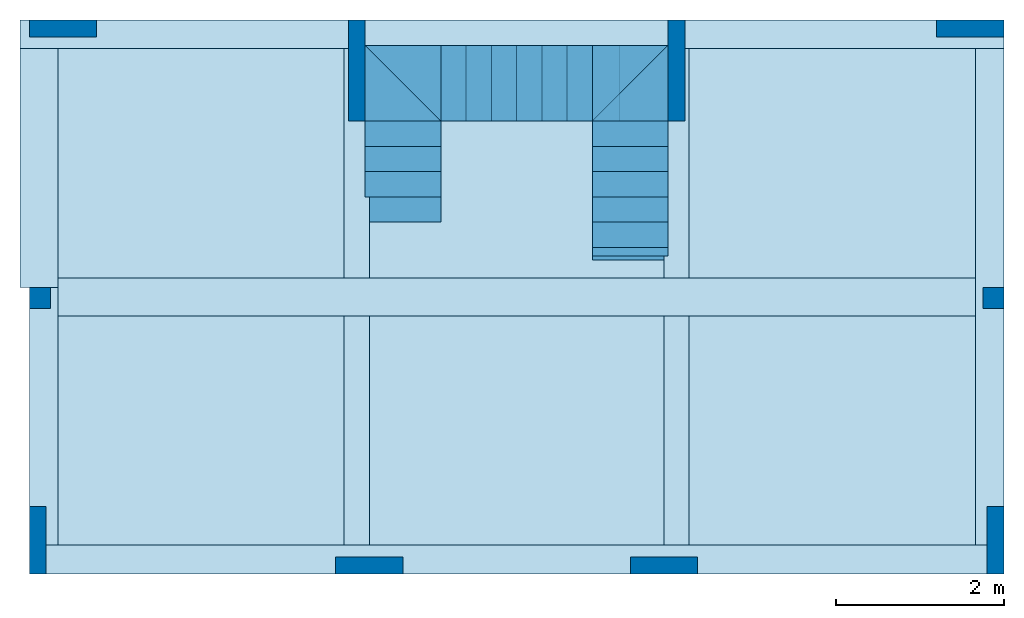
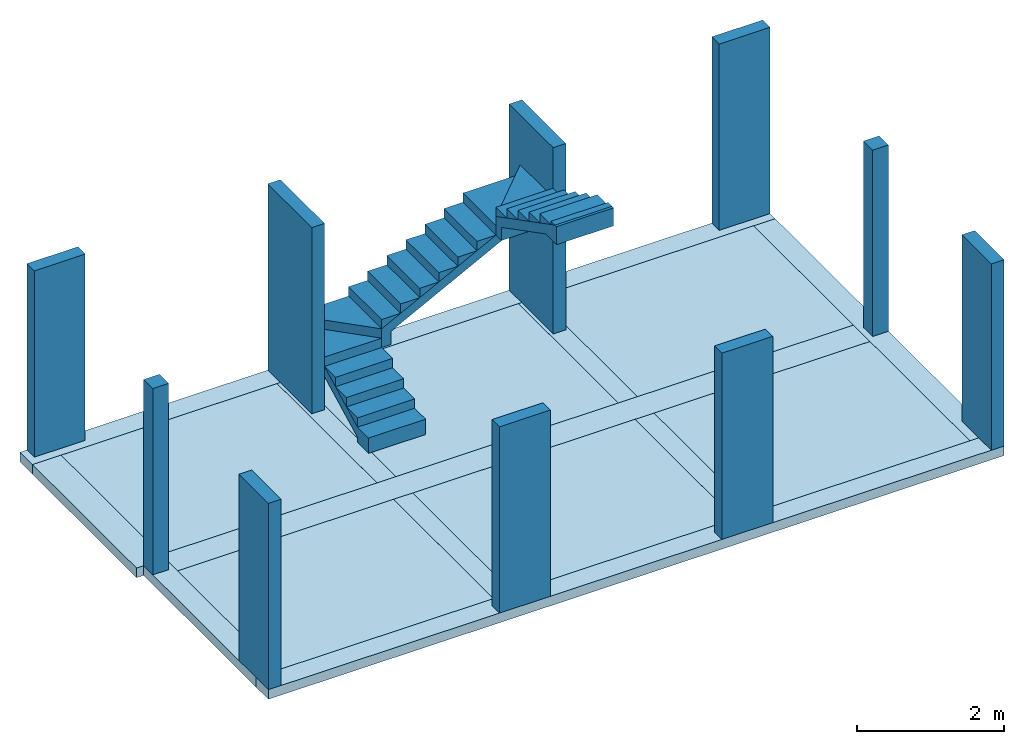
# One storey: 19 stairs, 16 slabs, 10 columns, 3 stair flights.
"""IFC4 building model written with IfcOpenShell, lengths in metres."""

from ifc_helpers import new_model, entity, si_unit, converted_unit, direction, frame, frame_2d, origin_with_axes, origin_2d_with_axis, place, context, subcontext, project, spatial, polyline, rectangle, outline, extrude, element, save


model = new_model("IFC4")

# Units and contexts
model_context = context("Model", 3, precision=1e-05, world=origin_with_axes(), true_north=direction((6.12323399573677e-17, 1.0)))
body_context = subcontext(model_context, "Body", "Model", "MODEL_VIEW")
ifc_project = project(units=[si_unit("LENGTHUNIT", "METRE"), si_unit("AREAUNIT", "SQUARE_METRE"), si_unit("VOLUMEUNIT", "CUBIC_METRE"), converted_unit("PLANEANGLEUNIT", "DEGREE", entity("IfcPlaneAngleMeasure", 0.017453292519943295), si_unit("PLANEANGLEUNIT", "RADIAN"), dimensions=[0, 0, 0, 0, 0, 0, 0])], contexts=[model_context])

# Site, building, storey
site = spatial("IfcSite", under=ifc_project, CompositionType="COMPLEX")
building = spatial("IfcBuilding", under=site, Name="Italian House", CompositionType="COMPLEX")
storey_placement = place(None, frame((0.0, 0.0, -0.300000011920929), z_axis=(0.0, 0.0, 1.0), x_axis=(1.0, 0.0, 0.0)))
storey = spatial("IfcBuildingStorey", under=building, at=storey_placement, Name="Piano terra")

# Columns
column_1_placement = place(storey_placement, frame((0.0, 0.0, 0.300000011920929), z_axis=(0.0, 0.0, 1.0), x_axis=(1.0, 0.0, 0.0)))
element("IfcColumn", 1, at=column_1_placement, inside=storey, Name="P008_1", PredefinedType="COLUMN", context=body_context, shape_type="SweptSolid", body=[
    extrude(rectangle(XDim=0.2, YDim=0.8, at=frame_2d((3.30681662608084e-18, 1.21430643318376e-17), x_axis=(1.0, 0.0))), frame((15.83, -6.18, 0.46), z_axis=(0.0, 0.0, 1.0), x_axis=(1.0, 0.0, 0.0)), (0.0, 0.0, 1.0), 3.1),
])
column_2_placement = place(storey_placement, frame((0.0, 0.0, 0.300000011920929), z_axis=(0.0, 0.0, 1.0), x_axis=(1.0, 0.0, 0.0)))
element("IfcColumn", 2, at=column_2_placement, inside=storey, Name="P004_1", PredefinedType="COLUMN", context=body_context, shape_type="SweptSolid", body=[
    extrude(rectangle(XDim=0.2, YDim=1.2, at=frame_2d((3.30681662608079e-18, -2.42861286636753e-17), x_axis=(1.0, 0.0))), frame((8.24, -0.599999999999998, 0.46), z_axis=(0.0, 0.0, 1.0), x_axis=(1.0, 0.0, 0.0)), (0.0, 0.0, 1.0), 3.1),
])
column_3_placement = place(storey_placement, frame((0.0, 0.0, 0.300000011920929), z_axis=(0.0, 0.0, 1.0), x_axis=(1.0, 0.0, 0.0)))
element("IfcColumn", 3, at=column_3_placement, inside=storey, Name="P005_1", PredefinedType="COLUMN", context=body_context, shape_type="SweptSolid", body=[
    extrude(rectangle(XDim=0.2, YDim=1.2, at=frame_2d((3.30681662608079e-18, -2.42861286636753e-17), x_axis=(1.0, 0.0))), frame((12.04, -0.599999999999997, 0.46), z_axis=(0.0, 0.0, 1.0), x_axis=(1.0, 0.0, 0.0)), (0.0, 0.0, 1.0), 3.1),
])
column_4_placement = place(storey_placement, frame((0.0, 0.0, 0.300000011920929), z_axis=(0.0, 0.0, 1.0), x_axis=(1.0, 0.0, 0.0)))
element("IfcColumn", 4, at=column_4_placement, inside=storey, Name="P010_1", PredefinedType="COLUMN", context=body_context, shape_type="SweptSolid", body=[
    extrude(rectangle(XDim=0.8, YDim=0.2, at=frame_2d((1.32272665043234e-17, 3.03576608295941e-18), x_axis=(1.0, 0.0))), frame((8.39000001192093, -6.48000000596046, 0.46), z_axis=(0.0, 0.0, 1.0), x_axis=(0.999999999999993, -1.19209275e-07, 0.0)), (0.0, 0.0, 1.0), 3.1),
])
column_5_placement = place(storey_placement, frame((0.0, 0.0, 0.300000011920929), z_axis=(0.0, 0.0, 1.0), x_axis=(1.0, 0.0, 0.0)))
element("IfcColumn", 5, at=column_5_placement, inside=storey, Name="P009_1", PredefinedType="COLUMN", context=body_context, shape_type="SweptSolid", body=[
    extrude(rectangle(XDim=0.8, YDim=0.2, at=frame_2d((1.32272665043234e-17, 3.03576608295941e-18), x_axis=(1.0, 0.0))), frame((11.8900000119209, -6.47999999403953, 0.46), z_axis=(0.0, 0.0, 1.0), x_axis=(0.999999999999993, -1.19209275e-07, 0.0)), (0.0, 0.0, 1.0), 3.1),
])
column_6_placement = place(storey_placement, frame((0.0, 0.0, 0.300000011920929), z_axis=(0.0, 0.0, 1.0), x_axis=(1.0, 0.0, 0.0)))
element("IfcColumn", 6, at=column_6_placement, inside=storey, Name="P002_1", PredefinedType="COLUMN", context=body_context, shape_type="SweptSolid", body=[
    extrude(rectangle(XDim=0.25, YDim=0.25, at=frame_2d((2.00577401909818e-18, 3.46944695195361e-18), x_axis=(1.0, 0.0))), frame((4.475, -3.305, 0.46), z_axis=(0.0, 0.0, 1.0), x_axis=(1.0, 0.0, 0.0)), (0.0, 0.0, 1.0), 3.1),
])
column_7_placement = place(storey_placement, frame((0.0, 0.0, 0.300000011920929), z_axis=(0.0, 0.0, 1.0), x_axis=(1.0, 0.0, 0.0)))
element("IfcColumn", 7, at=column_7_placement, inside=storey, Name="P007_1", PredefinedType="COLUMN", context=body_context, shape_type="SweptSolid", body=[
    extrude(rectangle(XDim=0.25, YDim=0.25, at=frame_2d((2.00577401909818e-18, 3.46944695195361e-18), x_axis=(1.0, 0.0))), frame((15.805, -3.305, 0.46), z_axis=(0.0, 0.0, 1.0), x_axis=(1.0, 0.0, 0.0)), (0.0, 0.0, 1.0), 3.1),
])
column_8_placement = place(storey_placement, frame((0.0, 0.0, 0.300000011920929), z_axis=(0.0, 0.0, 1.0), x_axis=(1.0, 0.0, 0.0)))
element("IfcColumn", 8, at=column_8_placement, inside=storey, Name="P003_1", PredefinedType="COLUMN", context=body_context, shape_type="SweptSolid", body=[
    extrude(rectangle(XDim=0.8, YDim=0.2, at=frame_2d((1.32272665043234e-17, 3.03576608295941e-18), x_axis=(1.0, 0.0))), frame((4.75, -0.0999999999999982, 0.46), z_axis=(0.0, 0.0, 1.0), x_axis=(1.0, 0.0, 0.0)), (0.0, 0.0, 1.0), 3.1),
])
column_9_placement = place(storey_placement, frame((0.0, 0.0, 0.300000011920929), z_axis=(0.0, 0.0, 1.0), x_axis=(1.0, 0.0, 0.0)))
element("IfcColumn", 9, at=column_9_placement, inside=storey, Name="P006_1", PredefinedType="COLUMN", context=body_context, shape_type="SweptSolid", body=[
    extrude(rectangle(XDim=0.8, YDim=0.2, at=frame_2d((1.32272665043234e-17, 3.03576608295941e-18), x_axis=(1.0, 0.0))), frame((15.53, -0.0999999999999959, 0.46), z_axis=(0.0, 0.0, 1.0), x_axis=(1.0, 0.0, 0.0)), (0.0, 0.0, 1.0), 3.1),
])
column_10_placement = place(storey_placement, frame((0.0, 0.0, 0.300000011920929), z_axis=(0.0, 0.0, 1.0), x_axis=(1.0, 0.0, 0.0)))
element("IfcColumn", 10, at=column_10_placement, inside=storey, Name="P001_1", PredefinedType="COLUMN", context=body_context, shape_type="SweptSolid", body=[
    extrude(rectangle(XDim=0.2, YDim=0.8, at=frame_2d((3.30681662608084e-18, 1.21430643318376e-17), x_axis=(1.0, 0.0))), frame((4.45, -6.18, 0.46), z_axis=(0.0, 0.0, 1.0), x_axis=(1.0, 0.0, 0.0)), (0.0, 0.0, 1.0), 3.1),
])

# Slabs
slab_1_placement = place(storey_placement, frame((0.0, 0.0, 0.300000011920929), z_axis=(0.0, 0.0, 1.0), x_axis=(1.0, 0.0, 0.0)))
element("IfcSlab", 11, at=slab_1_placement, inside=storey, Name="Cordolo001", PredefinedType="FLOOR", context=body_context, shape_type="SweptSolid", body=[
    extrude(rectangle(XDim=11.58, YDim=0.34, at=origin_2d_with_axis()), frame((10.14, -6.41, 0.46), z_axis=(0.0, 0.0, 1.0), x_axis=(1.0, 0.0, 0.0)), (0.0, 0.0, -1.0), 0.16),
])
slab_2_placement = place(storey_placement, frame((0.0, 0.0, 0.300000011920929), z_axis=(0.0, 0.0, 1.0), x_axis=(1.0, 0.0, 0.0)))
element("IfcSlab", 12, at=slab_2_placement, inside=storey, Name="Cordolo002", PredefinedType="FLOOR", context=body_context, shape_type="SweptSolid", body=[
    extrude(rectangle(XDim=10.9, YDim=0.45, at=frame_2d((0.0, 2.8421709430404e-14), x_axis=(1.0, 0.0))), frame((10.14, -3.29, 0.46), z_axis=(0.0, 0.0, 1.0), x_axis=(1.0, 0.0, 0.0)), (0.0, 0.0, -1.0), 0.16),
])
slab_3_placement = place(storey_placement, frame((0.0, 0.0, 0.300000011920929), z_axis=(0.0, 0.0, 1.0), x_axis=(1.0, 0.0, 0.0)))
element("IfcSlab", 13, at=slab_3_placement, inside=storey, Name="Cordolo003", PredefinedType="FLOOR", context=body_context, shape_type="SweptSolid", body=[
    extrude(rectangle(XDim=11.69, YDim=0.34, at=frame_2d((-9.09494701772928e-13, 0.0), x_axis=(0.999999999999993, 1.19209275002871e-07))), frame((10.0849999797344, -0.169999303221791, 0.46), z_axis=(0.0, 0.0, 1.0), x_axis=(1.0, 0.0, 0.0)), (0.0, 0.0, -1.0), 0.16),
])
slab_4_placement = place(storey_placement, frame((0.0, 0.0, 0.300000011920929), z_axis=(0.0, 0.0, 1.0), x_axis=(1.0, 0.0, 0.0)))
element("IfcSlab", 14, at=slab_4_placement, inside=storey, Name="Cordolo004", PredefinedType="FLOOR", context=body_context, shape_type="SweptSolid", body=[
    extrude(rectangle(XDim=0.34, YDim=5.9, at=frame_2d((2.8421709430404e-14, 0.0), x_axis=(1.0, 0.0))), frame((15.76, -3.29, 0.46), z_axis=(0.0, 0.0, 1.0), x_axis=(1.0, 0.0, 0.0)), (0.0, 0.0, -1.0), 0.16),
])
slab_5_placement = place(storey_placement, frame((0.0, 0.0, 0.300000011920929), z_axis=(0.0, 0.0, 1.0), x_axis=(1.0, 0.0, 0.0)))
element("IfcSlab", 15, at=slab_5_placement, inside=storey, Name="Cordolo005_1", PredefinedType="FLOOR", context=body_context, shape_type="SweptSolid", body=[
    extrude(rectangle(XDim=0.3, YDim=2.725, at=origin_2d_with_axis()), frame((12.04, -4.8775, 0.46), z_axis=(0.0, 0.0, 1.0), x_axis=(1.0, 0.0, 0.0)), (0.0, 0.0, -1.0), 0.16),
])
slab_6_placement = place(storey_placement, frame((0.0, 0.0, 0.300000011920929), z_axis=(0.0, 0.0, 1.0), x_axis=(1.0, 0.0, 0.0)))
element("IfcSlab", 16, at=slab_6_placement, inside=storey, Name="Cordolo005_2", PredefinedType="FLOOR", context=body_context, shape_type="SweptSolid", body=[
    extrude(rectangle(XDim=0.3, YDim=2.725, at=origin_2d_with_axis()), frame((12.04, -1.7025, 0.46), z_axis=(0.0, 0.0, 1.0), x_axis=(1.0, 0.0, 0.0)), (0.0, 0.0, -1.0), 0.16),
])
slab_7_placement = place(storey_placement, frame((0.0, 0.0, 0.300000011920929), z_axis=(0.0, 0.0, 1.0), x_axis=(1.0, 0.0, 0.0)))
element("IfcSlab", 17, at=slab_7_placement, inside=storey, Name="Cordolo006_1", PredefinedType="FLOOR", context=body_context, shape_type="SweptSolid", body=[
    extrude(rectangle(XDim=0.3, YDim=2.725, at=origin_2d_with_axis()), frame((8.24, -4.8775, 0.46), z_axis=(0.0, 0.0, 1.0), x_axis=(1.0, 0.0, 0.0)), (0.0, 0.0, -1.0), 0.16),
])
slab_8_placement = place(storey_placement, frame((0.0, 0.0, 0.300000011920929), z_axis=(0.0, 0.0, 1.0), x_axis=(1.0, 0.0, 0.0)))
element("IfcSlab", 18, at=slab_8_placement, inside=storey, Name="Cordolo006_2", PredefinedType="FLOOR", context=body_context, shape_type="SweptSolid", body=[
    extrude(rectangle(XDim=0.3, YDim=2.725, at=origin_2d_with_axis()), frame((8.24, -1.7025, 0.46), z_axis=(0.0, 0.0, 1.0), x_axis=(1.0, 0.0, 0.0)), (0.0, 0.0, -1.0), 0.16),
])
slab_9_placement = place(storey_placement, frame((0.0, 0.0, 0.300000011920929), z_axis=(0.0, 0.0, 1.0), x_axis=(1.0, 0.0, 0.0)))
element("IfcSlab", 19, at=slab_9_placement, inside=storey, Name="Cordolo007_1", PredefinedType="FLOOR", context=body_context, shape_type="SweptSolid", body=[
    extrude(rectangle(XDim=0.34, YDim=3.06, at=frame_2d((2.8421709430404e-14, 0.0), x_axis=(1.0, 0.0))), frame((4.52, -4.71, 0.46), z_axis=(0.0, 0.0, 1.0), x_axis=(1.0, 0.0, 0.0)), (0.0, 0.0, -1.0), 0.16),
])
slab_10_placement = place(storey_placement, frame((0.0, 0.0, 0.300000011920929), z_axis=(0.0, 0.0, 1.0), x_axis=(1.0, 0.0, 0.0)))
element("IfcSlab", 20, at=slab_10_placement, inside=storey, Name="Cordolo007_2", PredefinedType="FLOOR", context=body_context, shape_type="SweptSolid", body=[
    extrude(rectangle(XDim=0.45, YDim=2.84, at=origin_2d_with_axis()), frame((4.465, -1.76, 0.46), z_axis=(0.0, 0.0, 1.0), x_axis=(1.0, 0.0, 0.0)), (0.0, 0.0, -1.0), 0.16),
])
slab_11_placement = place(storey_placement, frame((0.0, 0.0, 0.300000011920929), z_axis=(0.0, 0.0, 1.0), x_axis=(1.0, 0.0, 0.0)))
element("IfcSlab", 21, at=slab_11_placement, inside=storey, Name="Solaio001", PredefinedType="FLOOR", context=body_context, shape_type="SweptSolid", body=[
    extrude(rectangle(XDim=3.4, YDim=2.725, at=origin_2d_with_axis()), frame((13.89, -4.8775, 0.46), z_axis=(0.0, 0.0, 1.0), x_axis=(1.0, 0.0, 0.0)), (0.0, 0.0, -1.0), 0.16),
])
slab_12_placement = place(storey_placement, frame((0.0, 0.0, 0.300000011920929), z_axis=(0.0, 0.0, 1.0), x_axis=(1.0, 0.0, 0.0)))
element("IfcSlab", 22, at=slab_12_placement, inside=storey, Name="Solaio002", PredefinedType="FLOOR", context=body_context, shape_type="SweptSolid", body=[
    extrude(rectangle(XDim=3.4, YDim=2.725, at=origin_2d_with_axis()), frame((13.89, -1.7025, 0.46), z_axis=(0.0, 0.0, 1.0), x_axis=(1.0, 0.0, 0.0)), (0.0, 0.0, -1.0), 0.16),
])
slab_13_placement = place(storey_placement, frame((0.0, 0.0, 0.300000011920929), z_axis=(0.0, 0.0, 1.0), x_axis=(1.0, 0.0, 0.0)))
element("IfcSlab", 23, at=slab_13_placement, inside=storey, Name="Solaio003", PredefinedType="FLOOR", context=body_context, shape_type="SweptSolid", body=[
    extrude(rectangle(XDim=3.5, YDim=2.725, at=origin_2d_with_axis()), frame((10.14, -4.8775, 0.46), z_axis=(0.0, 0.0, 1.0), x_axis=(1.0, 0.0, 0.0)), (0.0, 0.0, -1.0), 0.16),
])
slab_14_placement = place(storey_placement, frame((0.0, 0.0, 0.300000011920929), z_axis=(0.0, 0.0, 1.0), x_axis=(1.0, 0.0, 0.0)))
element("IfcSlab", 24, at=slab_14_placement, inside=storey, Name="Solaio004", PredefinedType="FLOOR", context=body_context, shape_type="SweptSolid", body=[
    extrude(rectangle(XDim=3.5, YDim=2.725, at=origin_2d_with_axis()), frame((10.14, -1.7025, 0.46), z_axis=(0.0, 0.0, 1.0), x_axis=(1.0, 0.0, 0.0)), (0.0, 0.0, -1.0), 0.16),
])
slab_15_placement = place(storey_placement, frame((0.0, 0.0, 0.300000011920929), z_axis=(0.0, 0.0, 1.0), x_axis=(1.0, 0.0, 0.0)))
element("IfcSlab", 25, at=slab_15_placement, inside=storey, Name="Solaio005", PredefinedType="FLOOR", context=body_context, shape_type="SweptSolid", body=[
    extrude(rectangle(XDim=3.4, YDim=2.725, at=origin_2d_with_axis()), frame((6.39, -4.8775, 0.46), z_axis=(0.0, 0.0, 1.0), x_axis=(1.0, 0.0, 0.0)), (0.0, 0.0, -1.0), 0.16),
])
slab_16_placement = place(storey_placement, frame((0.0, 0.0, 0.300000011920929), z_axis=(0.0, 0.0, 1.0), x_axis=(1.0, 0.0, 0.0)))
element("IfcSlab", 26, at=slab_16_placement, inside=storey, Name="Solaio006", PredefinedType="FLOOR", context=body_context, shape_type="SweptSolid", body=[
    extrude(rectangle(XDim=3.4, YDim=2.725, at=origin_2d_with_axis()), frame((6.39, -1.7025, 0.46), z_axis=(0.0, 0.0, 1.0), x_axis=(1.0, 0.0, 0.0)), (0.0, 0.0, -1.0), 0.16),
])

# Stair flight
stair_flight_1_placement = place(storey_placement, frame((0.0, 0.0, 0.300000011920929), z_axis=(0.0, 0.0, 1.0), x_axis=(1.0, 0.0, 0.0)))
element("IfcStairFlight", 27, at=stair_flight_1_placement, inside=storey, Name="Rampa001", PredefinedType="STRAIGHT", context=body_context, shape_type="SweptSolid", body=[
    extrude(outline(polyline([(-0.348824988322179, -0.330952457494503), (-0.348824988322179, -0.630952457494503), (-0.0938249883221786, -0.630952457494503), (-0.0938249883221786, -0.330952457494503), (0.371175011677821, 0.569047542505497), (0.371175011677821, 0.895830652277815), (-0.262662928371209, -0.330952457494503), (-0.348824988322179, -0.330952457494503)])), frame((8.34, -1.7690475425055, 0.808824988322179), z_axis=(-1.0, 0.0, 0.0), x_axis=(0.0, 0.0, 1.0)), (0.0, 0.0, -1.0), 0.9),
])

# Stair
stair_1_placement = place(storey_placement, frame((0.0, 0.0, 0.300000011920929), z_axis=(0.0, 0.0, 1.0), x_axis=(1.0, 0.0, 0.0)))
element("IfcStair", 28, at=stair_1_placement, inside=storey, Name="001", PredefinedType="STRAIGHT_RUN_STAIR", context=body_context, shape_type="SweptSolid", body=[
    extrude(rectangle(XDim=0.155, YDim=0.9, at=origin_2d_with_axis()), frame((8.34, -0.750000000000004, 1.2575), z_axis=(1.0, 0.0, 0.0), x_axis=(0.0, 0.0, -1.0)), (0.0, 0.0, 1.0), 0.9),
])

# Stair flight
stair_flight_2_placement = place(storey_placement, frame((0.0, 0.0, 0.300000011920929), z_axis=(0.0, 0.0, 1.0), x_axis=(1.0, 0.0, 0.0)))
element("IfcStairFlight", 29, at=stair_flight_2_placement, inside=storey, Name="Rampa002", PredefinedType="STRAIGHT", context=body_context, shape_type="SweptSolid", body=[
    extrude(outline(polyline([(-0.915939929248618, -0.683419381763706), (-0.915939929248618, -0.373419381763706), (0.884060070751382, 0.556580618236294), (1.2108431805237, 0.556580618236294), (-0.765939929248618, -0.464757321812736), (-0.765939929248618, -0.683419381763706), (-0.915939929248618, -0.683419381763706)])), frame((10.1559399292486, -0.300000000000004, 1.86341938176371), z_axis=(0.0, -1.0, 0.0), x_axis=(1.0, 0.0, 0.0)), (0.0, 2e-16, 1.0), 0.9),
])

# Stair
stair_2_placement = place(storey_placement, frame((0.0, 0.0, 0.300000011920929), z_axis=(0.0, 0.0, 1.0), x_axis=(1.0, 0.0, 0.0)))
element("IfcStair", 30, at=stair_2_placement, inside=storey, Name="002", PredefinedType="STRAIGHT_RUN_STAIR", context=body_context, shape_type="SweptSolid", body=[
    extrude(rectangle(XDim=0.155, YDim=0.9, at=frame_2d((0.0, 0.0), x_axis=(0.0, -1.0))), frame((11.49, -0.300000000000004, 2.4975), z_axis=(0.0, -1.0, 0.0), x_axis=(1.0, 0.0, 0.0)), (0.0, 2e-16, 1.0), 0.9),
])

# Stair flight
stair_flight_3_placement = place(storey_placement, frame((0.0, 0.0, 0.300000011920929), z_axis=(0.0, 0.0, 1.0), x_axis=(1.0, 0.0, 0.0)))
element("IfcStairFlight", 31, at=stair_flight_3_placement, inside=storey, Name="Rampa003", PredefinedType="STRAIGHT", context=body_context, shape_type="SweptSolid", body=[
    extrude(outline(polyline([(0.621646602380388, 0.813090019944861), (0.311646602380388, 0.813090019944861), (-0.518353397619612, -0.793361592958365), (-0.518353397619612, -0.836909980055139), (-0.218353397619612, -0.836909980055139), (-0.218353397619612, -0.539499541440358), (0.402984542429418, 0.663090019944861), (0.621646602380388, 0.663090019944861), (0.621646602380388, 0.813090019944861)])), frame((11.94, -2.01309001994486, 3.04164660238039), z_axis=(1.0, 0.0, 0.0), x_axis=(0.0, 0.0, -1.0)), (0.0, 0.0, -1.0), 0.9),
])

# Stairs
stair_3_placement = place(storey_placement, frame((0.0, 0.0, 0.300000011920929), z_axis=(0.0, 0.0, 1.0), x_axis=(1.0, 0.0, 0.0)))
element("IfcStair", 32, at=stair_3_placement, inside=storey, Name="Gradino002", PredefinedType="STRAIGHT_RUN_STAIR", context=body_context, shape_type="SweptSolid", body=[
    extrude(outline(polyline([(0.103333333333333, -0.1), (-0.0516666666666666, 0.2), (-0.0516666666666666, -0.1), (0.103333333333333, -0.1)])), frame((8.34, -2.0, 0.818333333333333), z_axis=(1.0, 0.0, 0.0), x_axis=(0.0, 0.0, -1.0)), (0.0, 0.0, 1.0), 0.9),
])
stair_4_placement = place(storey_placement, frame((0.0, 0.0, 0.300000011920929), z_axis=(0.0, 0.0, 1.0), x_axis=(1.0, 0.0, 0.0)))
element("IfcStair", 33, at=stair_4_placement, inside=storey, Name="Gradino003", PredefinedType="STRAIGHT_RUN_STAIR", context=body_context, shape_type="SweptSolid", body=[
    extrude(outline(polyline([(-0.103333333333333, -0.1), (0.0516666666666666, -0.1), (0.0516666666666666, 0.2), (-0.103333333333333, -0.1)])), frame((8.34, -1.7, 0.973333333333333), z_axis=(-1.0, 0.0, 0.0), x_axis=(0.0, 0.0, 1.0)), (0.0, 0.0, -1.0), 0.9),
])
stair_5_placement = place(storey_placement, frame((0.0, 0.0, 0.300000011920929), z_axis=(0.0, 0.0, 1.0), x_axis=(1.0, 0.0, 0.0)))
element("IfcStair", 34, at=stair_5_placement, inside=storey, Name="Gradino004", PredefinedType="STRAIGHT_RUN_STAIR", context=body_context, shape_type="SweptSolid", body=[
    extrude(outline(polyline([(-0.103333333333333, -0.1), (0.0516666666666667, -0.1), (0.0516666666666667, 0.2), (-0.103333333333333, -0.1)])), frame((8.34, -1.4, 1.12833333333333), z_axis=(-1.0, 0.0, 0.0), x_axis=(0.0, 0.0, 1.0)), (0.0, 0.0, -1.0), 0.9),
])
stair_6_placement = place(storey_placement, frame((0.0, 0.0, 0.300000011920929), z_axis=(0.0, 0.0, 1.0), x_axis=(1.0, 0.0, 0.0)))
element("IfcStair", 35, at=stair_6_placement, inside=storey, Name="Gradino006", PredefinedType="STRAIGHT_RUN_STAIR", context=body_context, shape_type="SweptSolid", body=[
    extrude(outline(polyline([(-0.6, 0.3), (0.3, 0.3), (0.3, -0.6), (-0.6, 0.3)])), frame((8.94, -0.600000000000004, 1.335), z_axis=(0.0, 0.0, 1.0), x_axis=(1.0, 0.0, 0.0)), (0.0, 0.0, 1.0), 0.155),
])
stair_7_placement = place(storey_placement, frame((0.0, 0.0, 0.300000011920929), z_axis=(0.0, 0.0, 1.0), x_axis=(1.0, 0.0, 0.0)))
element("IfcStair", 36, at=stair_7_placement, inside=storey, Name="Gradino007", PredefinedType="STRAIGHT_RUN_STAIR", context=body_context, shape_type="SweptSolid", body=[
    extrude(outline(polyline([(-0.1, -0.103333333333333), (-0.1, 0.0516666666666667), (0.2, 0.0516666666666667), (-0.1, -0.103333333333333)])), frame((9.34, -0.300000000000004, 1.59333333333333), z_axis=(0.0, -1.0, 0.0), x_axis=(1.0, 0.0, 0.0)), (0.0, 2e-16, 1.0), 0.9),
])
stair_8_placement = place(storey_placement, frame((0.0, 0.0, 0.300000011920929), z_axis=(0.0, 0.0, 1.0), x_axis=(1.0, 0.0, 0.0)))
element("IfcStair", 37, at=stair_8_placement, inside=storey, Name="Gradino008", PredefinedType="STRAIGHT_RUN_STAIR", context=body_context, shape_type="SweptSolid", body=[
    extrude(outline(polyline([(-0.1, -0.103333333333333), (-0.1, 0.0516666666666667), (0.2, 0.0516666666666667), (-0.1, -0.103333333333333)])), frame((9.64, -0.300000000000004, 1.74833333333333), z_axis=(0.0, -1.0, 0.0), x_axis=(1.0, 0.0, 0.0)), (0.0, 2e-16, 1.0), 0.9),
])
stair_9_placement = place(storey_placement, frame((0.0, 0.0, 0.300000011920929), z_axis=(0.0, 0.0, 1.0), x_axis=(1.0, 0.0, 0.0)))
element("IfcStair", 38, at=stair_9_placement, inside=storey, Name="Gradino009", PredefinedType="STRAIGHT_RUN_STAIR", context=body_context, shape_type="SweptSolid", body=[
    extrude(outline(polyline([(-0.1, -0.103333333333333), (-0.1, 0.0516666666666667), (0.2, 0.0516666666666667), (-0.1, -0.103333333333333)])), frame((9.94, -0.300000000000004, 1.90333333333333), z_axis=(0.0, -1.0, 0.0), x_axis=(1.0, 0.0, 0.0)), (0.0, 2e-16, 1.0), 0.9),
])
stair_10_placement = place(storey_placement, frame((0.0, 0.0, 0.300000011920929), z_axis=(0.0, 0.0, 1.0), x_axis=(1.0, 0.0, 0.0)))
element("IfcStair", 39, at=stair_10_placement, inside=storey, Name="Gradino010", PredefinedType="STRAIGHT_RUN_STAIR", context=body_context, shape_type="SweptSolid", body=[
    extrude(outline(polyline([(-0.1, -0.103333333333333), (-0.1, 0.0516666666666665), (0.2, 0.0516666666666665), (-0.1, -0.103333333333333)])), frame((10.24, -0.300000000000004, 2.05833333333333), z_axis=(0.0, -1.0, 0.0), x_axis=(1.0, 0.0, 0.0)), (0.0, 2e-16, 1.0), 0.9),
])
stair_11_placement = place(storey_placement, frame((0.0, 0.0, 0.300000011920929), z_axis=(0.0, 0.0, 1.0), x_axis=(1.0, 0.0, 0.0)))
element("IfcStair", 40, at=stair_11_placement, inside=storey, Name="Gradino011", PredefinedType="STRAIGHT_RUN_STAIR", context=body_context, shape_type="SweptSolid", body=[
    extrude(outline(polyline([(-0.1, -0.103333333333333), (-0.1, 0.0516666666666665), (0.2, 0.0516666666666665), (-0.1, -0.103333333333333)])), frame((10.54, -0.300000000000004, 2.21333333333333), z_axis=(0.0, -1.0, 0.0), x_axis=(1.0, 0.0, 0.0)), (0.0, 2e-16, 1.0), 0.9),
])
stair_12_placement = place(storey_placement, frame((0.0, 0.0, 0.300000011920929), z_axis=(0.0, 0.0, 1.0), x_axis=(1.0, 0.0, 0.0)))
element("IfcStair", 41, at=stair_12_placement, inside=storey, Name="Gradino012", PredefinedType="STRAIGHT_RUN_STAIR", context=body_context, shape_type="SweptSolid", body=[
    extrude(outline(polyline([(-0.1, -0.103333333333333), (-0.1, 0.0516666666666665), (0.2, 0.0516666666666665), (-0.1, -0.103333333333333)])), frame((10.84, -0.300000000000004, 2.36833333333333), z_axis=(0.0, -1.0, 0.0), x_axis=(1.0, 0.0, 0.0)), (0.0, 2e-16, 1.0), 0.9),
])
stair_13_placement = place(storey_placement, frame((0.0, 0.0, 0.300000011920929), z_axis=(0.0, 0.0, 1.0), x_axis=(1.0, 0.0, 0.0)))
element("IfcStair", 42, at=stair_13_placement, inside=storey, Name="Gradino014", PredefinedType="STRAIGHT_RUN_STAIR", context=body_context, shape_type="SweptSolid", body=[
    extrude(outline(polyline([(-0.6, -0.3), (0.3, -0.3), (0.3, 0.6), (-0.6, -0.3)])), frame((11.64, -0.900000000000004, 2.575), z_axis=(0.0, 0.0, 1.0), x_axis=(1.0, 0.0, 0.0)), (0.0, 0.0, 1.0), 0.155),
])
stair_14_placement = place(storey_placement, frame((0.0, 0.0, 0.300000011920929), z_axis=(0.0, 0.0, 1.0), x_axis=(1.0, 0.0, 0.0)))
element("IfcStair", 43, at=stair_14_placement, inside=storey, Name="Gradino015", PredefinedType="STRAIGHT_RUN_STAIR", context=body_context, shape_type="SweptSolid", body=[
    extrude(outline(polyline([(0.103333333333333, 0.1), (-0.0516666666666665, 0.1), (-0.0516666666666665, -0.2), (0.103333333333333, 0.1)])), frame((11.94, -1.3, 2.83333333333333), z_axis=(1.0, 0.0, 0.0), x_axis=(0.0, 0.0, -1.0)), (0.0, 0.0, -1.0), 0.9),
])
stair_15_placement = place(storey_placement, frame((0.0, 0.0, 0.300000011920929), z_axis=(0.0, 0.0, 1.0), x_axis=(1.0, 0.0, 0.0)))
element("IfcStair", 44, at=stair_15_placement, inside=storey, Name="Gradino016", PredefinedType="STRAIGHT_RUN_STAIR", context=body_context, shape_type="SweptSolid", body=[
    extrude(outline(polyline([(0.103333333333333, 0.1), (-0.0516666666666665, 0.1), (-0.0516666666666665, -0.2), (0.103333333333333, 0.1)])), frame((11.94, -1.6, 2.98833333333333), z_axis=(1.0, 0.0, 0.0), x_axis=(0.0, 0.0, -1.0)), (0.0, 0.0, -1.0), 0.9),
])
stair_16_placement = place(storey_placement, frame((0.0, 0.0, 0.300000011920929), z_axis=(0.0, 0.0, 1.0), x_axis=(1.0, 0.0, 0.0)))
element("IfcStair", 45, at=stair_16_placement, inside=storey, Name="Gradino017", PredefinedType="STRAIGHT_RUN_STAIR", context=body_context, shape_type="SweptSolid", body=[
    extrude(outline(polyline([(0.103333333333333, 0.1), (-0.0516666666666665, 0.1), (-0.0516666666666665, -0.2), (0.103333333333333, 0.1)])), frame((11.94, -1.9, 3.14333333333333), z_axis=(1.0, 0.0, 0.0), x_axis=(0.0, 0.0, -1.0)), (0.0, 0.0, -1.0), 0.9),
])
stair_17_placement = place(storey_placement, frame((0.0, 0.0, 0.300000011920929), z_axis=(0.0, 0.0, 1.0), x_axis=(1.0, 0.0, 0.0)))
element("IfcStair", 46, at=stair_17_placement, inside=storey, Name="Gradino018", PredefinedType="STRAIGHT_RUN_STAIR", context=body_context, shape_type="SweptSolid", body=[
    extrude(outline(polyline([(0.103333333333333, 0.1), (-0.0516666666666665, 0.1), (-0.0516666666666665, -0.2), (0.103333333333333, 0.1)])), frame((11.94, -2.2, 3.29833333333333), z_axis=(1.0, 0.0, 0.0), x_axis=(0.0, 0.0, -1.0)), (0.0, 0.0, -1.0), 0.9),
])
stair_18_placement = place(storey_placement, frame((0.0, 0.0, 0.300000011920929), z_axis=(0.0, 0.0, 1.0), x_axis=(1.0, 0.0, 0.0)))
element("IfcStair", 47, at=stair_18_placement, inside=storey, Name="Gradino019", PredefinedType="STRAIGHT_RUN_STAIR", context=body_context, shape_type="SweptSolid", body=[
    extrude(outline(polyline([(0.103333333333333, 0.1), (-0.0516666666666665, 0.1), (-0.0516666666666665, -0.2), (0.103333333333333, 0.1)])), frame((11.94, -2.5, 3.45333333333333), z_axis=(1.0, 0.0, 0.0), x_axis=(0.0, 0.0, -1.0)), (0.0, 0.0, -1.0), 0.9),
])
stair_19_placement = place(storey_placement, frame((0.0, 0.0, 0.300000011920929), z_axis=(0.0, 0.0, 1.0), x_axis=(1.0, 0.0, 0.0)))
element("IfcStair", 48, at=stair_19_placement, inside=storey, Name="Gradino020", PredefinedType="STRAIGHT_RUN_STAIR", context=body_context, shape_type="SweptSolid", body=[
    extrude(outline(polyline([(0.0366666666666665, 0.0354838709677419), (-0.0183333333333335, 0.0354838709677419), (-0.0183333333333335, -0.0709677419354834), (0.0366666666666665, 0.0354838709677419)])), frame((11.94, -2.73548387096775, 3.54166666666667), z_axis=(1.0, 0.0, 0.0), x_axis=(0.0, 0.0, -1.0)), (0.0, 0.0, -1.0), 0.9),
])

save(model, "model.ifc")
